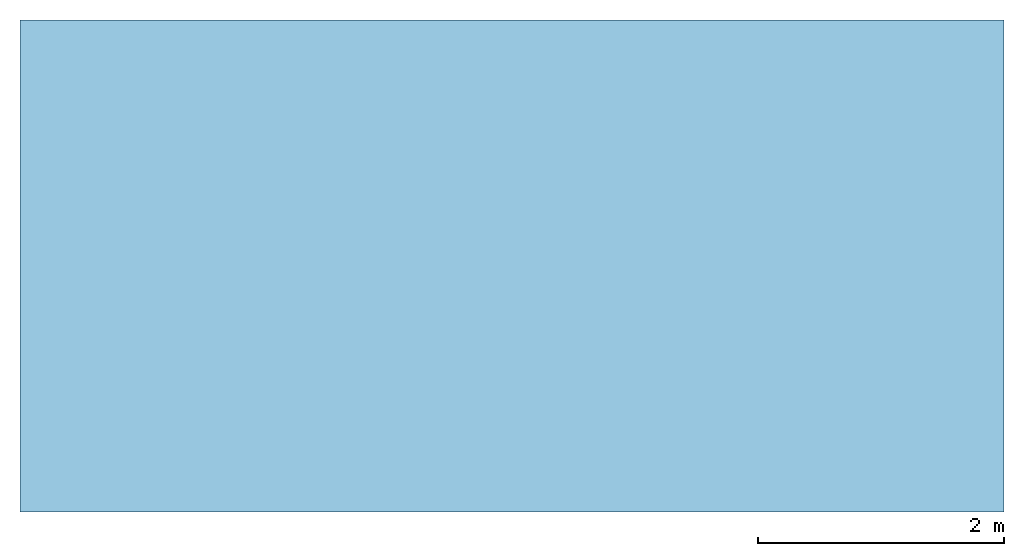
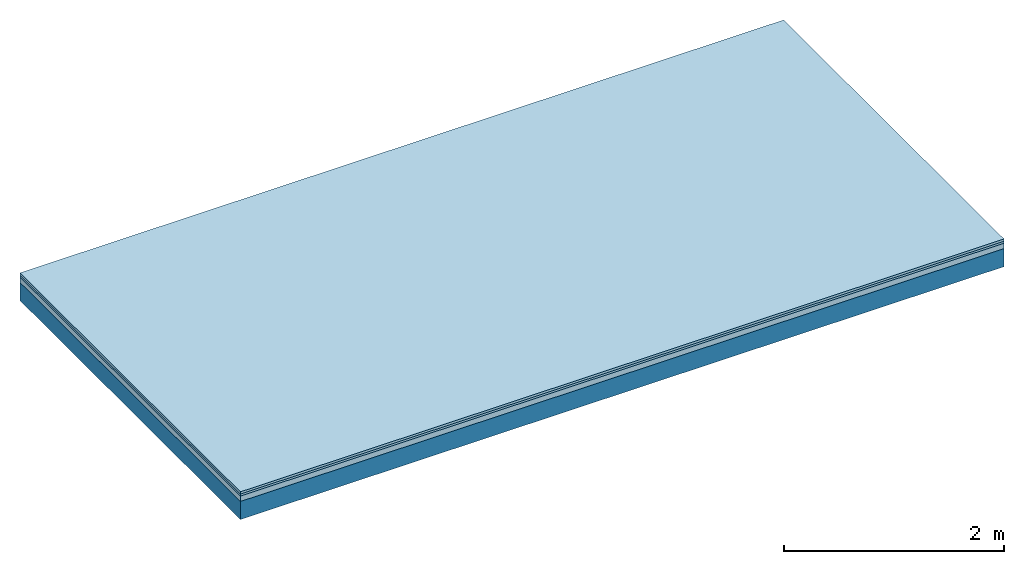
# One storey: 3 plates, 1 member, 1 element without a shape of its own.
"""IFC4 building model written with IfcOpenShell, lengths in metres."""

from ifc_helpers import new_model, si_unit, derived_unit, direction, frame, frame_2d, origin, origin_with_axes, place, context, project, spatial, rectangle, extrude, material, layer, layer_set, type_object, element, aggregate, save


model = new_model("IFC4")

# Units and contexts
plan_context = context("Plan", 3, precision=1e-05, world=origin(), true_north=direction((0.0, 1.0)))
model_context = context("Model", 3, precision=1e-05, world=origin(), true_north=direction((0.0, 1.0)))
ifc_project = project(units=[si_unit("LENGTHUNIT", "METRE"), derived_unit("SOUNDPRESSUREUNIT", [(si_unit("PRESSUREUNIT", "PASCAL", prefix="MICRO"), 0)]), si_unit("ENERGYUNIT", "JOULE", prefix="MEGA"), si_unit("MASSUNIT", "GRAM", prefix="KILO"), derived_unit("THERMALTRANSMITTANCEUNIT", [(si_unit("POWERUNIT", "WATT"), 1), (si_unit("AREAUNIT", "SQUARE_METRE"), -1), (si_unit("THERMODYNAMICTEMPERATUREUNIT", "KELVIN"), -1)]), derived_unit("AREADENSITYUNIT", [(si_unit("MASSUNIT", "GRAM", prefix="KILO"), 1), (si_unit("AREAUNIT", "SQUARE_METRE"), -1)]), derived_unit("USERDEFINED", [(si_unit("ENERGYUNIT", "JOULE", prefix="MEGA"), 1), (si_unit("AREAUNIT", "SQUARE_METRE"), -1)])], contexts=[plan_context, model_context])

# Site, building, storey
site = spatial("IfcSite", under=ifc_project)
building_placement = place(None, origin())
building = spatial("IfcBuilding", under=site, at=building_placement)
storey_placement = place(building_placement, origin())
storey = spatial("IfcBuildingStorey", under=building, at=storey_placement)

# Slab, member, plates
ifc_material_1 = material(Name="Floor heating system Therm38 longitudinal", Category="03.007")
ifc_layer_1 = layer(ifc_material_1, 0.025, Name="On-material")
ifc_material_2 = material(Category="10.009")
ifc_layer_2 = layer(ifc_material_2, 0.022, Name="Impact sound insulation")
ifc_material_3 = material(Category="03.011")
ifc_layer_3 = layer(ifc_material_3, 0.06, Name="on Supporting structure")
ifc_layer_4 = layer(None, 0.2, Name="Supporting structure")
ifc_layer_set = layer_set([ifc_layer_1, ifc_layer_2, ifc_layer_3, ifc_layer_4])
slab_type = type_object("IfcSlabType", Name="A1091", PredefinedType="NOTDEFINED", material=ifc_layer_set)
slab_placement = place(None, frame((0.0, 0.0, 0.0), z_axis=(0.0, 0.0, -1.0), x_axis=(1.0, 0.0, 0.0)))
slab = element("IfcSlab", 1, at=slab_placement, inside=storey, type_object=slab_type, material=ifc_layer_set, Name="Slab #1")
ifc_material_4 = material()
member_placement = place(slab_placement, origin())
member = element("IfcMember", 2, at=member_placement, material=ifc_material_4, Name="Supporting structure", context=plan_context, shape_type="SweptSolid", body=[
    extrude(rectangle(XDim=1.0, YDim=0.2, at=frame_2d((0.5, 0.1), x_axis=(1.0, 0.0))), frame((0.0, 4.0, 0.107), z_axis=(0.0, -1.0, 0.0), x_axis=(1.0, 0.0, 0.0)), (0.0, 0.0, 1.0), 4.0),
    extrude(rectangle(XDim=1.0, YDim=0.2, at=frame_2d((0.5, 0.1), x_axis=(1.0, 0.0))), frame((1.0, 4.0, 0.107), z_axis=(0.0, -1.0, 0.0), x_axis=(1.0, 0.0, 0.0)), (0.0, 0.0, 1.0), 4.0),
    extrude(rectangle(XDim=1.0, YDim=0.2, at=frame_2d((0.5, 0.1), x_axis=(1.0, 0.0))), frame((2.0, 4.0, 0.107), z_axis=(0.0, -1.0, 0.0), x_axis=(1.0, 0.0, 0.0)), (0.0, 0.0, 1.0), 4.0),
    extrude(rectangle(XDim=1.0, YDim=0.2, at=frame_2d((0.5, 0.1), x_axis=(1.0, 0.0))), frame((3.0, 4.0, 0.107), z_axis=(0.0, -1.0, 0.0), x_axis=(1.0, 0.0, 0.0)), (0.0, 0.0, 1.0), 4.0),
    extrude(rectangle(XDim=1.0, YDim=0.2, at=frame_2d((0.5, 0.1), x_axis=(1.0, 0.0))), frame((4.0, 4.0, 0.107), z_axis=(0.0, -1.0, 0.0), x_axis=(1.0, 0.0, 0.0)), (0.0, 0.0, 1.0), 4.0),
    extrude(rectangle(XDim=1.0, YDim=0.2, at=frame_2d((0.5, 0.1), x_axis=(1.0, 0.0))), frame((5.0, 4.0, 0.107), z_axis=(0.0, -1.0, 0.0), x_axis=(1.0, 0.0, 0.0)), (0.0, 0.0, 1.0), 4.0),
    extrude(rectangle(XDim=1.0, YDim=0.2, at=frame_2d((0.5, 0.1), x_axis=(1.0, 0.0))), frame((6.0, 4.0, 0.107), z_axis=(0.0, -1.0, 0.0), x_axis=(1.0, 0.0, 0.0)), (0.0, 0.0, 1.0), 4.0),
    extrude(rectangle(XDim=1.0, YDim=0.2, at=frame_2d((0.5, 0.1), x_axis=(1.0, 0.0))), frame((7.0, 4.0, 0.107), z_axis=(0.0, -1.0, 0.0), x_axis=(1.0, 0.0, 0.0)), (0.0, 0.0, 1.0), 4.0),
])
plate_1_placement = place(slab_placement, origin())
plate_1 = element("IfcPlate", 3, at=plate_1_placement, material=ifc_material_1, Name="On-material", context=plan_context, shape_type="SweptSolid", body=[
    extrude(rectangle(XDim=8.0, YDim=4.0, at=frame_2d((4.0, 2.0), x_axis=(1.0, 0.0))), origin_with_axes(), (0.0, 0.0, 1.0), 0.025),
])
plate_2_placement = place(slab_placement, origin())
plate_2 = element("IfcPlate", 4, at=plate_2_placement, material=ifc_material_2, Name="Impact sound insulation", context=plan_context, shape_type="SweptSolid", body=[
    extrude(rectangle(XDim=8.0, YDim=4.0, at=frame_2d((4.0, 2.0), x_axis=(1.0, 0.0))), frame((0.0, 0.0, 0.025), z_axis=(0.0, 0.0, 1.0), x_axis=(1.0, 0.0, 0.0)), (0.0, 0.0, 1.0), 0.022),
])
plate_3_placement = place(slab_placement, origin())
plate_3 = element("IfcPlate", 5, at=plate_3_placement, material=ifc_material_3, Name="on Supporting structure", context=plan_context, shape_type="SweptSolid", body=[
    extrude(rectangle(XDim=8.0, YDim=4.0, at=frame_2d((4.0, 2.0), x_axis=(1.0, 0.0))), frame((0.0, 0.0, 0.047), z_axis=(0.0, 0.0, 1.0), x_axis=(1.0, 0.0, 0.0)), (0.0, 0.0, 1.0), 0.06),
])
aggregate(slab, [plate_1, plate_2, plate_3, member])

save(model, "model.ifc")
